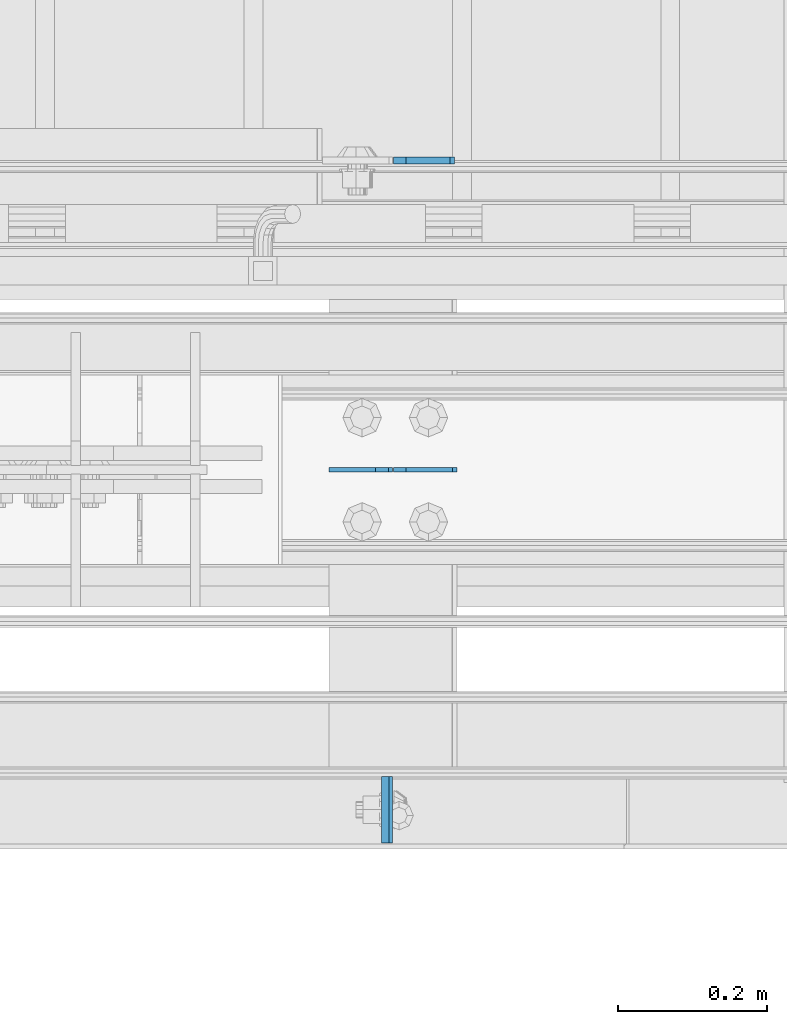
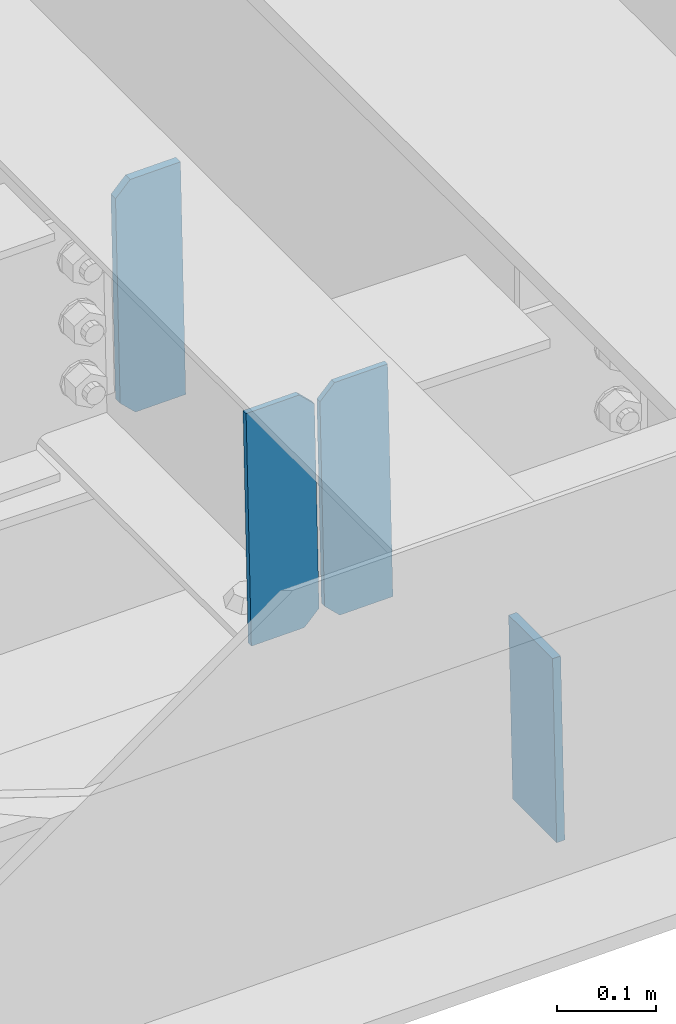
# One storey, part 3552 of 3843: 4 plates, 2 elements without a shape of their own.
"""IFC2X3 building model written with IfcOpenShell, lengths in millimetres."""

from ifc_helpers import new_model, si_unit, frame, origin_with_axes, place, context, subcontext, project, spatial, faceted_brep, material, type_object, element, aggregate, save


model = new_model("IFC2X3")

# Units and contexts
model_context = context("Model", 3, precision=1e-05, world=origin_with_axes())
body_context = subcontext(model_context, "Body", "Model", "MODEL_VIEW")
ifc_project = project(units=[si_unit("LENGTHUNIT", "METRE", prefix="MILLI"), si_unit("AREAUNIT", "SQUARE_METRE"), si_unit("VOLUMEUNIT", "CUBIC_METRE"), si_unit("MASSUNIT", "GRAM", prefix="KILO"), si_unit("TIMEUNIT", "SECOND"), si_unit("PLANEANGLEUNIT", "RADIAN"), si_unit("SOLIDANGLEUNIT", "STERADIAN"), si_unit("THERMODYNAMICTEMPERATUREUNIT", "DEGREE_CELSIUS"), si_unit("LUMINOUSINTENSITYUNIT", "LUMEN")], contexts=[model_context])

# Site, building, storey
site_placement = place(None, origin_with_axes())
site = spatial("IfcSite", under=ifc_project, at=site_placement, CompositionType="ELEMENT")
building_placement = place(site_placement, origin_with_axes())
building = spatial("IfcBuilding", under=site, at=building_placement, Name="Undefined", CompositionType="ELEMENT")
storey_placement = place(building_placement, origin_with_axes())
storey = spatial("IfcBuildingStorey", under=building, at=storey_placement, Name="Undefined", CompositionType="ELEMENT", Elevation=0.0)

# Assembly, plate
assembly_1_placement = place(storey_placement, origin_with_axes())
assembly_1 = element("IfcElementAssembly", 1, at=assembly_1_placement, inside=storey, Name="BEAM", AssemblyPlace="NOTDEFINED", PredefinedType="RIGID_FRAME")
ifc_material = material(Name="STEEL/A572-50")
plate_type_1 = type_object("IfcPlateType", PredefinedType="NOTDEFINED")
plate_1_placement = place(assembly_1_placement, frame((82180.6886954243, 14498.6375, 46656.3368328607), z_axis=(0.0, 1.0, 0.0), x_axis=(0.0211520550054438, 0.0, -0.999776270257025)))
plate_1 = element("IfcPlate", 2, at=plate_1_placement, type_object=plate_type_1, material=ifc_material, Name="PLATE", context=body_context, shape_type="Brep", body=[
    faceted_brep([(0.0, -4.76249999999709, 0.0), (0.0, -4.76249999999709, 88.9000015258789), (0.0, 4.76249999999709, 88.9000015258789), (0.0, 4.76249999999709, 0.0), (228.600006102781, -4.7625000004191, 88.9000015257589), (228.600006102781, 4.76249999954598, 88.9000015257443), (228.600006103079, -4.7625000004482, 7.27595761418343e-12), (228.600006103079, 4.76249999954598, -7.27595761418343e-12)], [[[0, 1, 2, 3]], [[1, 4, 5, 2]], [[4, 6, 7, 5]], [[6, 0, 3, 7]], [[5, 7, 3, 2]], [[6, 4, 1, 0]]]),
])
aggregate(assembly_1, [plate_1])

# Assembly, plates
assembly_2_placement = place(storey_placement, origin_with_axes())
assembly_2 = element("IfcElementAssembly", 3, at=assembly_2_placement, inside=storey, Name="BEAM", AssemblyPlace="NOTDEFINED", PredefinedType="RIGID_FRAME")
plate_type_2 = type_object("IfcPlateType", PredefinedType="NOTDEFINED")
plate_2_placement = place(assembly_2_placement, frame((82276.696478346, 14998.7000000062, 46396.3719368191), z_axis=(-0.0211520980073474, 0.0, 0.999776269347241), x_axis=(-0.999776270257024, 0.0, -0.0211520550054595)))
plate_2 = element("IfcPlate", 4, at=plate_2_placement, type_object=plate_type_2, material=ifc_material, Name="STIFFENER", context=body_context, shape_type="Brep", body=[
    faceted_brep([(0.0, -3.17499999999927, 0.0), (6.83940015733242e-10, -3.17499999996653, 288.924999998613), (6.54836185276508e-10, 3.17500000001746, 288.924999998591), (0.0, 3.17499999999927, 0.0), (61.9125003828667, -3.17499999997744, 288.924999998599), (61.9125003828522, 3.17500000002838, 288.924999998584), (79.3750000013097, -3.17499999997744, 271.462500380039), (79.375000001266, 3.17500000002838, 271.462500380017), (79.375000000713, -3.17499999999927, 17.4624996185448), (79.3750000006694, 3.17500000000291, 17.462499618523), (61.9125003821828, -3.17499999999563, -1.45519152283669e-11), (61.9125003821682, 3.17500000000655, -2.91038304567337e-11)], [[[0, 1, 2, 3]], [[1, 4, 5, 2]], [[4, 6, 7, 5]], [[6, 8, 9, 7]], [[8, 10, 11, 9]], [[10, 0, 3, 11]], [[5, 7, 9, 11, 3, 2]], [[10, 8, 6, 4, 1, 0]]]),
])
plate_3_placement = place(assembly_2_placement, frame((82190.9906576557, 14998.7000000062, 46394.5586732174), z_axis=(-0.0211520980073474, 0.0, 0.999776269347241), x_axis=(-0.999776270257024, 0.0, -0.0211520550054595)))
plate_3 = element("IfcPlate", 5, at=plate_3_placement, type_object=plate_type_2, material=ifc_material, Name="STIFFENER", context=body_context, shape_type="Brep", body=[
    faceted_brep([(5.82076609134674e-11, -3.17499999999927, 17.4624996185667), (6.25732354819775e-10, -3.17499999997744, 271.462500380054), (5.82076609134674e-10, 3.17500000002474, 271.462500380039), (0.0, 3.17500000000655, 17.4624996185521), (17.462499619156, -3.17499999997744, 288.924999998606), (17.4624996191269, 3.17500000002474, 288.924999998591), (79.3750000013242, -3.17500000025029, 288.924999998591), (79.3750000013097, 3.1749999997337, 288.92499999857), (79.3750000006548, -3.17500000026484, -2.18278728425503e-11), (79.3750000006403, 3.17499999969732, -2.91038304567337e-11), (17.4624996184866, -3.17500000000291, 7.27595761418343e-12), (17.462499618443, 3.17500000000291, -7.27595761418343e-12)], [[[0, 1, 2, 3]], [[1, 4, 5, 2]], [[4, 6, 7, 5]], [[6, 8, 9, 7]], [[8, 10, 11, 9]], [[10, 0, 3, 11]], [[5, 7, 9, 11, 3, 2]], [[10, 8, 6, 4, 1, 0]]]),
])
plate_type_3 = type_object("IfcPlateType", PredefinedType="NOTDEFINED")
plate_4_placement = place(assembly_2_placement, frame((82197.3392369662, 15413.0375, 46394.6929890397), z_axis=(-0.0211520980073474, 0.0, 0.999776269347241), x_axis=(0.999776270257024, 0.0, 0.0211520550054619)))
plate_4 = element("IfcPlate", 6, at=plate_4_placement, type_object=plate_type_3, material=ifc_material, Name="PLATE", context=body_context, shape_type="Brep", body=[
    faceted_brep([(-1.45519152283669e-11, -4.76250000000073, 17.4624996184939), (-3.34694050252438e-10, -4.76250000000073, 271.462500379137), (-3.34694050252438e-10, 4.76250000000073, 271.462500379137), (-1.45519152283669e-11, 4.76250000000073, 17.4624996184939), (17.4624996182974, -4.76250000000073, 288.924999997646), (17.4624996182974, 4.76250000000073, 288.924999997646), (76.2000000009575, -4.76250000000073, 288.924999997696), (76.2000000009575, 4.76250000000073, 288.924999997696), (76.2000000012922, -4.76250000000073, 7.27595761418343e-11), (76.2000000012922, 4.76250000000073, 7.27595761418343e-11), (17.4624996186321, -4.76250000000073, 7.27595761418343e-12), (17.4624996186321, 4.76250000000073, 7.27595761418343e-12)], [[[0, 1, 2, 3]], [[1, 4, 5, 2]], [[4, 6, 7, 5]], [[6, 8, 9, 7]], [[8, 10, 11, 9]], [[10, 0, 3, 11]], [[5, 7, 9, 11, 3, 2]], [[10, 8, 6, 4, 1, 0]]]),
])
aggregate(assembly_2, [plate_4, plate_2, plate_3])

save(model, "model.ifc")
